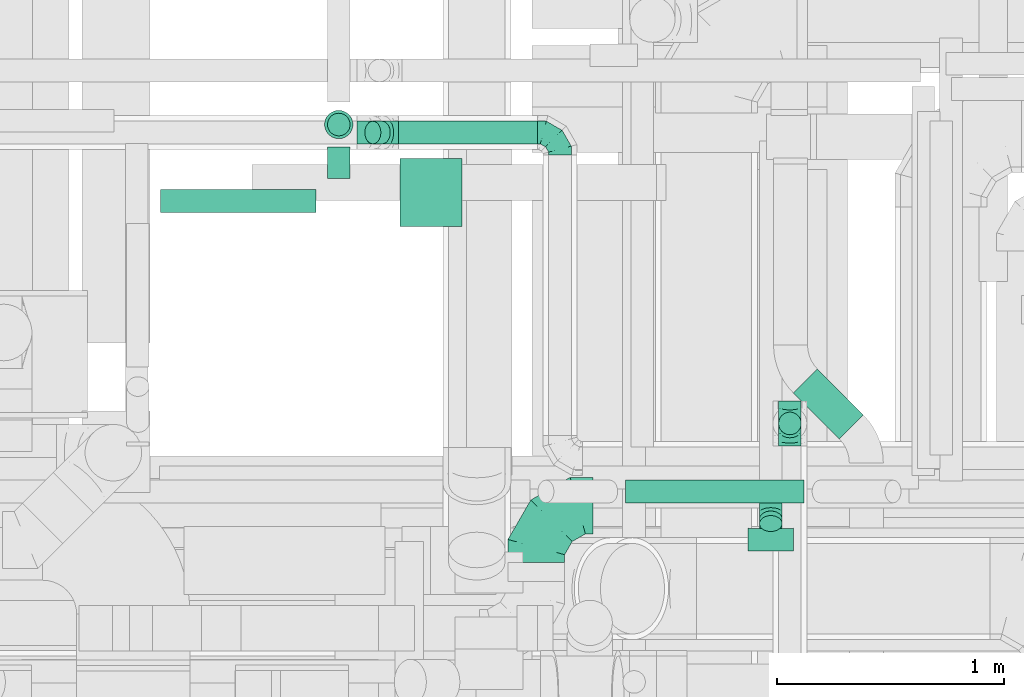
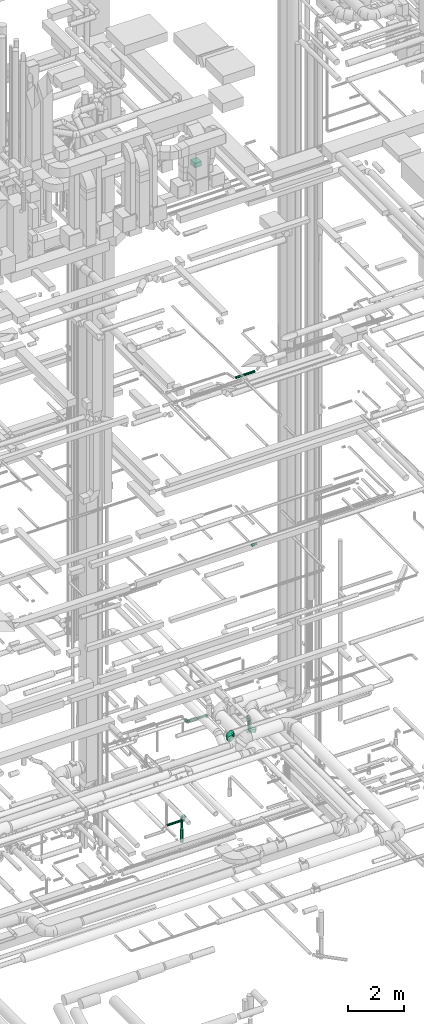
# One storey, part 255 of 337: 11 flow segments, 8 flow fittings.
"""IFC2X3 building model written with IfcOpenShell, lengths in millimetres."""

import ifcopenshell
import ifcopenshell.guid

model = None  # the IFC model being written
_history = None  # IfcOwnerHistory: only IFC2X3 demands one
_inside = {}  # id of a spatial element -> (the spatial element, [elements in it])
_under = {}  # id of a project, library or spatial element -> (it, [spatial elements below it])
_declared = {}  # id of a project -> (the project, [libraries it declares])
_typed = {}  # id of a type object -> (the type object, [elements of that type])
_made_of = {}  # id of a material, layer set ... -> (it, [elements and type objects made of it])


def new_model(schema):
    """Start an empty IFC model of exactly this schema.

    Asked for "IFC4X3", IfcOpenShell would pick the latest addendum, in which some entities
    have other attributes; the version numbers below select the first issue.
    IFC2X3 requires an IfcOwnerHistory on every rooted entity: one is made here for all.
    """
    global model, _history
    if schema == "IFC4X3":
        model = ifcopenshell.file(schema_version=(4, 3, 0, 0))
    else:
        model = ifcopenshell.file(schema=schema)
    _inside.clear()
    _under.clear()
    _declared.clear()
    _typed.clear()
    _made_of.clear()
    _history = None
    if model.schema == "IFC2X3":
        org = make("IfcOrganization", Name="unknown")
        user = make(
            "IfcPersonAndOrganization",
            ThePerson=make("IfcPerson", FamilyName="unknown"),
            TheOrganization=org,
        )
        app = make(
            "IfcApplication",
            ApplicationDeveloper=org,
            Version="unknown",
            ApplicationFullName="unknown",
            ApplicationIdentifier="unknown",
        )
        _history = make(
            "IfcOwnerHistory",
            OwningUser=user,
            OwningApplication=app,
            ChangeAction="ADDED",
            CreationDate=0,
        )
    return model


def make(cls, **values):
    """One entity of the class cls with the attributes given. An attribute that is None is left unset."""
    return model.create_entity(
        cls, **{name: value for name, value in values.items() if value is not None}
    )


def entity(cls, *values):
    """Any entity or typed value of the class cls, its attributes in the order of the schema. None: left unset."""
    e = model.create_entity(cls)
    for i, value in enumerate(values):
        if value is not None:
            e[i] = value
    return e


def rooted(cls, **values):
    """An entity with a GlobalId (a new one), such as an element, a storey or a relation."""
    return make(cls, GlobalId=ifcopenshell.guid.new(), OwnerHistory=_history, **values)


def si_unit(unit_type, name, prefix=None):
    """IfcSIUnit, for example si_unit("LENGTHUNIT", "METRE", prefix="MILLI")."""
    return make("IfcSIUnit", UnitType=unit_type, Prefix=prefix, Name=name)


def converted_unit(unit_type, name, factor, base, dimensions=None, offset=None):
    """IfcConversionBasedUnit, such as the inch: factor (a typed value) times the base unit."""
    return make(
        "IfcConversionBasedUnit"
        if offset is None
        else "IfcConversionBasedUnitWithOffset",
        ConversionOffset=offset,
        Dimensions=None
        if dimensions is None
        else entity("IfcDimensionalExponents", *dimensions),
        UnitType=unit_type,
        Name=name,
        ConversionFactor=make(
            "IfcMeasureWithUnit", ValueComponent=factor, UnitComponent=base
        ),
    )


def derived_unit(unit_type, elements):
    """IfcDerivedUnit: a product of units, each with its exponent."""
    return make(
        "IfcDerivedUnit",
        Elements=[
            make("IfcDerivedUnitElement", Unit=unit, Exponent=power)
            for unit, power in elements
        ],
        UnitType=unit_type,
    )


def assignment(units):
    """IfcUnitAssignment: the units of a project."""
    return None if units is None else make("IfcUnitAssignment", Units=units)


def point(xyz):
    """IfcCartesianPoint."""
    return None if xyz is None else make("IfcCartesianPoint", Coordinates=xyz)


def direction(xyz):
    """IfcDirection."""
    return None if xyz is None else make("IfcDirection", DirectionRatios=xyz)


def frame(location, z_axis=None, x_axis=None):
    """IfcAxis2Placement3D, a coordinate frame: its origin and axes. An axis left out is left unset."""
    return make(
        "IfcAxis2Placement3D",
        Location=point(location),
        Axis=direction(z_axis),
        RefDirection=direction(x_axis),
    )


def frame_2d(location, x_axis=None):
    """IfcAxis2Placement2D, a coordinate frame in the plane: its origin and x axis."""
    return make(
        "IfcAxis2Placement2D", Location=point(location), RefDirection=direction(x_axis)
    )


def origin():
    """The frame at (0, 0, 0) with its axes left unset."""
    return frame((0.0, 0.0, 0.0))


def origin_2d_with_axis():
    """The frame at (0, 0) in the plane with the x axis (1, 0) written out."""
    return frame_2d((0.0, 0.0), x_axis=(1.0, 0.0))


def place(relative_to, where):
    """IfcLocalPlacement: puts the frame where relative to a parent placement (None: the world)."""
    return make(
        "IfcLocalPlacement", PlacementRelTo=relative_to, RelativePlacement=where
    )


def context(
    kind, dimensions, precision=None, world=None, true_north=None, identifier=None
):
    """IfcGeometricRepresentationContext, for example the 3D "Model" context."""
    return make(
        "IfcGeometricRepresentationContext",
        ContextIdentifier=identifier,
        ContextType=kind,
        CoordinateSpaceDimension=dimensions,
        Precision=precision,
        WorldCoordinateSystem=world,
        TrueNorth=true_north,
    )


def subcontext(parent, identifier, kind, view, scale=None):
    """IfcGeometricRepresentationSubContext, for example "Body" below "Model"."""
    return make(
        "IfcGeometricRepresentationSubContext",
        ContextIdentifier=identifier,
        ContextType=kind,
        ParentContext=parent,
        TargetScale=scale,
        TargetView=view,
    )


def project(units=None, contexts=None):
    """IfcProject with its units and contexts."""
    return rooted(
        "IfcProject",
        Name="project",
        RepresentationContexts=contexts,
        UnitsInContext=assignment(units),
    )


def spatial(cls, under=None, at=None, **own):
    """A site, building, storey or space (cls), placed at a placement, below another one or the project."""
    s = rooted(cls, ObjectPlacement=at, **own)
    if under is not None:
        _under.setdefault(under.id(), (under, []))[1].append(s)
    return s


def profile(cls, at=None, kind="AREA", **sizes):
    """A parametric profile (cls). Its sizes go by their IFC names, for example OverallWidth=200.0."""
    return make(cls, ProfileType=kind, Position=at, **sizes)


def rectangle(**sizes):
    """IfcRectangleProfileDef."""
    return profile("IfcRectangleProfileDef", **sizes)


def circle(**sizes):
    """IfcCircleProfileDef."""
    return profile("IfcCircleProfileDef", **sizes)


def extrude(swept, where, along, depth):
    """IfcExtrudedAreaSolid: the profile swept, set in the frame where, extruded along a direction by depth."""
    return make(
        "IfcExtrudedAreaSolid",
        SweptArea=swept,
        Position=where,
        ExtrudedDirection=direction(along),
        Depth=depth,
    )


def faces_of(points, faces, orient=None, outer=None):
    """IfcFace entities. A face is a list of loops; a loop is a list of indices into points, from 0.

    orient and outer hold one flag for each loop. By default every Orientation is true, the
    first loop of a face is its IfcFaceOuterBound and the others are IfcFaceBound.
    """
    made = []
    for i, loops in enumerate(faces):
        bounds = []
        for j, loop in enumerate(loops):
            is_outer = j == 0 if outer is None else outer[i][j]
            bounds.append(
                make(
                    "IfcFaceOuterBound" if is_outer else "IfcFaceBound",
                    Bound=make("IfcPolyLoop", Polygon=[points[k] for k in loop]),
                    Orientation=True if orient is None else orient[i][j],
                )
            )
        made.append(make("IfcFace", Bounds=bounds))
    return made


def faceted_brep(points, faces, orient=None, outer=None, voids=None):
    """IfcFacetedBrep: a solid bounded by flat faces; with voids (closed shells), ...WithVoids."""
    shared = [point(p) for p in points]
    hull = make("IfcClosedShell", CfsFaces=faces_of(shared, faces, orient, outer))
    if voids is None:
        return make("IfcFacetedBrep", Outer=hull)
    return make(
        "IfcFacetedBrepWithVoids",
        Outer=hull,
        Voids=[
            make(cls, CfsFaces=faces_of(shared, fs, o, b)) for cls, fs, o, b in voids
        ],
    )


def shape(context_of_items, identifier, shape_type, items):
    """IfcShapeRepresentation: the items that make up one representation, for example the "Body"."""
    return make(
        "IfcShapeRepresentation",
        ContextOfItems=context_of_items,
        RepresentationIdentifier=identifier,
        RepresentationType=shape_type,
        Items=items,
    )


def source(mapping_origin, context_of_items, identifier, shape_type, items):
    """IfcRepresentationMap: a shape defined once, which mapped items show again and again."""
    return make(
        "IfcRepresentationMap",
        MappingOrigin=mapping_origin,
        MappedRepresentation=shape(context_of_items, identifier, shape_type, items),
    )


def transform(
    local_origin,
    x_axis=None,
    y_axis=None,
    z_axis=None,
    scale=None,
    scale2=None,
    scale3=None,
    uniform=True,
):
    """IfcCartesianTransformationOperator3D, or its non-uniform kind. x_axis, y_axis, z_axis: its Axis1, 2, 3."""
    if uniform:
        return make(
            "IfcCartesianTransformationOperator3D",
            Axis1=direction(x_axis),
            Axis2=direction(y_axis),
            LocalOrigin=point(local_origin),
            Scale=scale,
            Axis3=direction(z_axis),
        )
    return make(
        "IfcCartesianTransformationOperator3DnonUniform",
        Axis1=direction(x_axis),
        Axis2=direction(y_axis),
        LocalOrigin=point(local_origin),
        Scale=scale,
        Axis3=direction(z_axis),
        Scale2=scale2,
        Scale3=scale3,
    )


def mapped(mapping_source, mapping_target):
    """IfcMappedItem: shows the shape of a source again, moved by a transform."""
    return make(
        "IfcMappedItem", MappingSource=mapping_source, MappingTarget=mapping_target
    )


def material(Name=None, Category=None):
    """IfcMaterial."""
    return make("IfcMaterial", Name=Name, Category=Category)


def made_of(thing, what):
    """Note that an element or type object is made of a material, layer set ...; save() writes the relation."""
    if what is not None:
        _made_of.setdefault(what.id(), (what, []))[1].append(thing)
    return thing


def type_object(cls, material=None, **own):
    """A type object (cls), such as IfcWallType, which elements share."""
    return made_of(rooted(cls, **own), material)


def type_shapes(of_type, sources):
    """Give a type object the sources (RepresentationMaps) that its elements show as mapped items."""
    of_type.RepresentationMaps = sources


def element(
    cls,
    number,
    at=None,
    inside=None,
    cuts=None,
    type_object=None,
    material=None,
    context=None,
    identifier="Body",
    shape_type=None,
    held_by="IfcProductDefinitionShape",
    body=None,
    shapes=None,
    **own,
):
    """One element of the class cls, such as IfcWall. Its Tag is "e" and its number.

    at: its placement. inside: the storey or other place that contains it. cuts: it is an
    opening in that element (IfcRelVoidsElement). A single representation is given by context,
    identifier, shape_type and body (its items); several are given by shapes. held_by: the class
    of the entity that holds the representations. save() writes the other relations.
    """
    e = rooted(cls, Tag="e%d" % number, ObjectPlacement=at, **own)
    if body is not None:
        shapes = [shape(context, identifier, shape_type, body)]
    if shapes is not None:
        e.Representation = make(held_by, Representations=shapes)
    if inside is not None:
        _inside.setdefault(inside.id(), (inside, []))[1].append(e)
    if cuts is not None:
        rooted(
            "IfcRelVoidsElement", RelatingBuildingElement=cuts, RelatedOpeningElement=e
        )
    if type_object is not None:
        _typed.setdefault(type_object.id(), (type_object, []))[1].append(e)
    return made_of(e, material)


def aggregate(whole, parts):
    """IfcRelAggregates: a whole, such as a stair, and the parts it consists of."""
    return rooted("IfcRelAggregates", RelatingObject=whole, RelatedObjects=parts)


def save(model, path):
    """Write the relations noted so far, then the file.

    IfcRelAggregates (storeys below a building ...), IfcRelContainedInSpatialStructure (elements
    in a storey), IfcRelDefinesByType, IfcRelAssociatesMaterial and IfcRelDeclares: one each for
    every whole, place, type object, material and project.
    """
    for whole, parts in _under.values():
        aggregate(whole, parts)
    for where, things in _inside.values():
        rooted(
            "IfcRelContainedInSpatialStructure",
            RelatedElements=things,
            RelatingStructure=where,
        )
    for kind, things in _typed.values():
        rooted("IfcRelDefinesByType", RelatedObjects=things, RelatingType=kind)
    for what, things in _made_of.values():
        rooted("IfcRelAssociatesMaterial", RelatedObjects=things, RelatingMaterial=what)
    for by, libraries in _declared.values():
        rooted("IfcRelDeclares", RelatingContext=by, RelatedDefinitions=libraries)
    model.write(path)


model = new_model("IFC2X3")

# Units and contexts
model_context = context("Model", 3, precision=0.01, world=origin(), true_north=direction((6.12303176911189e-17, 1.0)))
body_context = subcontext(model_context, "Body", "Model", "MODEL_VIEW")
ifc_project = project(units=[si_unit("LENGTHUNIT", "METRE", prefix="MILLI"), si_unit("AREAUNIT", "SQUARE_METRE"), si_unit("VOLUMEUNIT", "CUBIC_METRE"), converted_unit("PLANEANGLEUNIT", "DEGREE", entity("IfcRatioMeasure", 0.0174532925199433), si_unit("PLANEANGLEUNIT", "RADIAN"), dimensions=[0, 0, 0, 0, 0, 0, 0]), si_unit("MASSUNIT", "GRAM", prefix="KILO"), derived_unit("MASSDENSITYUNIT", [(si_unit("MASSUNIT", "GRAM", prefix="KILO"), 1), (si_unit("LENGTHUNIT", "METRE"), -3)]), derived_unit("MOMENTOFINERTIAUNIT", [(si_unit("LENGTHUNIT", "METRE"), 4)]), si_unit("TIMEUNIT", "SECOND"), si_unit("FREQUENCYUNIT", "HERTZ"), si_unit("THERMODYNAMICTEMPERATUREUNIT", "DEGREE_CELSIUS"), derived_unit("THERMALTRANSMITTANCEUNIT", [(si_unit("MASSUNIT", "GRAM", prefix="KILO"), 1), (si_unit("THERMODYNAMICTEMPERATUREUNIT", "KELVIN"), -1), (si_unit("TIMEUNIT", "SECOND"), -3)]), derived_unit("VOLUMETRICFLOWRATEUNIT", [(si_unit("LENGTHUNIT", "METRE"), 3), (si_unit("TIMEUNIT", "SECOND"), -1)]), derived_unit("MASSFLOWRATEUNIT", [(si_unit("MASSUNIT", "GRAM", prefix="KILO"), 1), (si_unit("TIMEUNIT", "SECOND"), -1)]), derived_unit("ROTATIONALFREQUENCYUNIT", [(si_unit("TIMEUNIT", "SECOND"), -1)]), si_unit("ELECTRICCURRENTUNIT", "AMPERE"), si_unit("ELECTRICVOLTAGEUNIT", "VOLT"), si_unit("POWERUNIT", "WATT"), si_unit("FORCEUNIT", "NEWTON", prefix="KILO"), si_unit("ILLUMINANCEUNIT", "LUX"), si_unit("LUMINOUSFLUXUNIT", "LUMEN"), si_unit("LUMINOUSINTENSITYUNIT", "CANDELA"), derived_unit("USERDEFINED", [(si_unit("MASSUNIT", "GRAM", prefix="KILO"), -1), (si_unit("LENGTHUNIT", "METRE"), -2), (si_unit("TIMEUNIT", "SECOND"), 3), (si_unit("LUMINOUSFLUXUNIT", "LUMEN"), 1)]), derived_unit("LINEARVELOCITYUNIT", [(si_unit("LENGTHUNIT", "METRE"), 1), (si_unit("TIMEUNIT", "SECOND"), -1)]), si_unit("PRESSUREUNIT", "PASCAL"), derived_unit("USERDEFINED", [(si_unit("LENGTHUNIT", "METRE"), -2), (si_unit("MASSUNIT", "GRAM", prefix="KILO"), 1), (si_unit("TIMEUNIT", "SECOND"), -2)]), derived_unit("LINEARFORCEUNIT", [(si_unit("MASSUNIT", "GRAM", prefix="KILO"), 1), (si_unit("LENGTHUNIT", "METRE"), 1), (si_unit("TIMEUNIT", "SECOND"), -2), (si_unit("LENGTHUNIT", "METRE"), -1)]), derived_unit("PLANARFORCEUNIT", [(si_unit("MASSUNIT", "GRAM", prefix="KILO"), 1), (si_unit("LENGTHUNIT", "METRE"), 1), (si_unit("TIMEUNIT", "SECOND"), -2), (si_unit("LENGTHUNIT", "METRE"), -2)])], contexts=[model_context])

# Site, building, storey
site_placement = place(None, origin())
site = spatial("IfcSite", under=ifc_project, at=site_placement, CompositionType="ELEMENT")
building_placement = place(site_placement, origin())
building = spatial("IfcBuilding", under=site, at=building_placement, CompositionType="ELEMENT")
storey_placement = place(building_placement, origin())
storey = spatial("IfcBuildingStorey", under=building, at=storey_placement, CompositionType="ELEMENT", Elevation=0.0)

# Flow segments
duct_segment_type_1 = type_object("IfcDuctSegmentType", PredefinedType="NOTDEFINED")
flow_segment_1_placement = place(storey_placement, frame((63295.52, 11348.91, 27525.0)))
element("IfcFlowSegment", 1, at=flow_segment_1_placement, inside=storey, type_object=duct_segment_type_1, context=body_context, shape_type="SweptSolid", body=[
    extrude(rectangle(XDim=274.500000000016, YDim=300.000000000001, at=origin_2d_with_axis()), frame((137.25, 150.0, 0.0), z_axis=(0.0, 0.0, 1.0), x_axis=(-1.0, 0.0, 0.0)), (0.0, 0.0, 1.0), 199.999999999998),
])
flow_segment_2_placement = place(storey_placement, frame((65032.36, 10410.46, 2975.0)))
element("IfcFlowSegment", 2, at=flow_segment_2_placement, inside=storey, type_object=duct_segment_type_1, context=body_context, shape_type="SweptSolid", body=[
    extrude(rectangle(XDim=286.740981921751, YDim=149.999999999996, at=origin_2d_with_axis()), frame((154.41, 154.41, 0.0), z_axis=(0.0, 0.0, 1.0), x_axis=(-0.707106781186551, 0.707106781186544, 0.0)), (0.0, 0.0, 1.0), 149.999999999999),
])
duct_segment_type_2 = type_object("IfcDuctSegmentType", PredefinedType="NOTDEFINED")
flow_segment_3_placement = place(storey_placement, frame((62240.26, 11408.94, -651.6)))
element("IfcFlowSegment", 3, at=flow_segment_3_placement, inside=storey, type_object=duct_segment_type_2, context=body_context, shape_type="SweptSolid", body=[
    extrude(circle(Radius=50.0, at=origin_2d_with_axis()), frame((0.0, 51.6, 51.6), z_axis=(1.0, 0.0, 0.0), x_axis=(0.0, -1.0, 0.0)), (0.0, 0.0, 1.0), 686.270819999998),
])
flow_segment_4_placement = place(storey_placement, frame((62974.94, 11560.54, -651.6)))
element("IfcFlowSegment", 4, at=flow_segment_4_placement, inside=storey, type_object=duct_segment_type_2, context=body_context, shape_type="SweptSolid", body=[
    extrude(circle(Radius=50.0, at=origin_2d_with_axis()), frame((51.6, 0.0, 51.6), z_axis=(0.0, 1.0, 0.0), x_axis=(1.0, 0.0, 0.0)), (0.0, 0.0, 1.0), 137.341930000023),
])
flow_segment_5_placement = place(storey_placement, frame((62974.94, 11746.29, -1176.74)))
element("IfcFlowSegment", 5, at=flow_segment_5_placement, inside=storey, type_object=duct_segment_type_2, context=body_context, shape_type="SweptSolid", body=[
    extrude(circle(Radius=50.0, at=origin_2d_with_axis()), frame((51.6, 51.6, 0.0), z_axis=(0.0, 0.0, 1.0), x_axis=(0.0, 1.0, 0.0)), (0.0, 0.0, 1.0), 476.736044499986),
])
flow_segment_6_placement = place(storey_placement, frame((62962.44, 11733.79, -1800.0)))
element("IfcFlowSegment", 6, at=flow_segment_6_placement, inside=storey, type_object=duct_segment_type_2, context=body_context, shape_type="SweptSolid", body=[
    extrude(circle(Radius=62.5, at=origin_2d_with_axis()), frame((64.1, 64.1, 0.0), z_axis=(0.0, 0.0, 1.0), x_axis=(0.0, 1.0, 0.0)), (0.0, 0.0, 1.0), 559.263955500005),
])
flow_segment_7_placement = place(storey_placement, frame((64292.48, 10127.45, 18768.4)))
element("IfcFlowSegment", 7, at=flow_segment_7_placement, inside=storey, type_object=duct_segment_type_2, context=body_context, shape_type="SweptSolid", body=[
    extrude(circle(Radius=50.0, at=origin_2d_with_axis()), frame((0.0, 51.6, 51.6), z_axis=(1.0, 0.0, 0.0), x_axis=(0.0, -1.0, 0.0)), (0.0, 0.0, 1.0), 787.157287525448),
])
flow_segment_8_placement = place(storey_placement, frame((63139.8, 11710.99, 3342.34)))
element("IfcFlowSegment", 8, at=flow_segment_8_placement, inside=storey, type_object=duct_segment_type_2, context=body_context, shape_type="SweptSolid", body=[
    extrude(circle(Radius=50.0, at=origin_2d_with_axis()), frame((78.37, 51.6, 36.95), z_axis=(-0.707106781186399, 0.0, 0.707106781186696), x_axis=(0.0, -1.0, 0.0)), (0.0, 0.0, 1.0), 58.5786437626603),
])
flow_segment_9_placement = place(storey_placement, frame((63288.88, 11710.99, 3298.4)))
element("IfcFlowSegment", 9, at=flow_segment_9_placement, inside=storey, type_object=duct_segment_type_2, context=body_context, shape_type="SweptSolid", body=[
    extrude(circle(Radius=50.0, at=origin_2d_with_axis()), frame((0.0, 51.6, 51.6), z_axis=(1.0, 0.0, 0.0), x_axis=(0.0, 1.0, 0.0)), (0.0, 0.0, 1.0), 613.303163484644),
])
flow_segment_10_placement = place(storey_placement, frame((64965.15, 10427.54, 3200.0)))
element("IfcFlowSegment", 10, at=flow_segment_10_placement, inside=storey, type_object=duct_segment_type_2, context=body_context, shape_type="SweptSolid", body=[
    extrude(circle(Radius=50.0, at=origin_2d_with_axis()), frame((51.6, 51.6, 0.0), z_axis=(0.0, 0.0, 1.0), x_axis=(-1.0, 0.0, 0.0)), (0.0, 0.0, 1.0), 350.000000000003),
])
flow_segment_11_placement = place(storey_placement, frame((64880.89, 10000.55, 11392.34)))
element("IfcFlowSegment", 11, at=flow_segment_11_placement, inside=storey, type_object=duct_segment_type_2, context=body_context, shape_type="SweptSolid", body=[
    extrude(circle(Radius=50.0, at=origin_2d_with_axis()), frame((51.6, 36.95, 56.95), z_axis=(0.0, 0.707106781186548, -0.707106781186548), x_axis=(-1.0, 0.0, 0.0)), (0.0, 0.0, 1.0), 28.2842712474572),
])

# Flow fittings
ifc_material = material()
duct_fitting_type_1 = type_object("IfcDuctFittingType", PredefinedType="NOTDEFINED", material=ifc_material)
shared_shape_1 = source(origin(), body_context, "Body", "Brep", [
    faceted_brep([(-100.0, 0.0, -50.0), (-100.0, -12.94, -48.3), (-100.0, -25.0, -43.3), (-100.0, -35.36, -35.36), (-100.0, -43.3, -25.0), (-100.0, -48.3, -12.94), (-100.0, -50.0, 0.0), (-100.0, -48.3, 12.94), (-100.0, -43.3, 25.0), (-100.0, -35.36, 35.36), (-100.0, -25.0, 43.3), (-100.0, -12.94, 48.3), (-100.0, 0.0, 50.0), (-100.0, 12.94, 48.3), (-100.0, 25.0, 43.3), (-100.0, 35.36, 35.36), (-100.0, 43.3, 25.0), (-100.0, 48.3, 12.94), (-100.0, 50.0, 0.0), (-100.0, 48.3, -12.94), (-100.0, 43.3, -25.0), (-100.0, 35.36, -35.36), (-100.0, 25.0, -43.3), (-100.0, 12.94, -48.3), (-76.67, 12.94, 48.3), (-79.9, 25.0, 43.3), (-73.21, 0.0, 50.0), (-82.68, 35.36, 35.36), (-86.15, 48.3, 12.94), (-86.6, 50.0, 0.0), (-84.81, 43.3, 25.0), (-84.81, 43.3, -25.0), (-82.68, 35.36, -35.36), (-86.15, 48.3, -12.94), (-76.67, 12.94, -48.3), (-73.21, 0.0, -50.0), (-79.9, 25.0, -43.3), (-69.74, -12.94, -48.3), (-66.51, -25.0, -43.3), (-63.73, -35.36, -35.36), (-61.6, -43.3, -25.0), (-60.26, -48.3, -12.94), (-59.81, -50.0, 0.0), (-60.26, -48.3, 12.94), (-61.6, -43.3, 25.0), (-63.73, -35.36, 35.36), (-66.51, -25.0, 43.3), (-69.74, -12.94, 48.3), (-36.27, 36.27, 48.3), (-45.1, 45.1, 43.3), (-26.79, 26.79, 50.0), (-52.68, 52.68, 35.36), (-58.49, 58.49, 25.0), (-62.15, 62.15, 12.94), (-63.4, 63.4, 0.0), (-62.15, 62.15, -12.94), (-58.49, 58.49, -25.0), (-52.68, 52.68, -35.36), (-36.27, 36.27, -48.3), (-26.79, 26.79, -50.0), (-45.1, 45.1, -43.3), (-17.32, 17.32, -48.3), (-8.49, 8.49, -43.3), (-0.91, 0.91, -35.36), (4.9, -4.9, -25.0), (8.56, -8.56, -12.94), (9.81, -9.81, 0.0), (8.56, -8.56, 12.94), (4.9, -4.9, 25.0), (-0.91, 0.91, 35.36), (-8.49, 8.49, 43.3), (-17.32, 17.32, 48.3), (-12.94, 76.67, 48.3), (-25.0, 79.9, 43.3), (0.0, 73.21, 50.0), (-35.36, 82.68, 35.36), (-43.3, 84.81, 25.0), (-48.3, 86.15, 12.94), (-50.0, 86.6, 0.0), (-48.3, 86.15, -12.94), (-43.3, 84.81, -25.0), (-35.36, 82.68, -35.36), (-12.94, 76.67, -48.3), (0.0, 73.21, -50.0), (-25.0, 79.9, -43.3), (12.94, 69.74, -48.3), (25.0, 66.51, -43.3), (35.36, 63.73, -35.36), (43.3, 61.6, -25.0), (48.3, 60.26, -12.94), (50.0, 59.81, 0.0), (48.3, 60.26, 12.94), (43.3, 61.6, 25.0), (35.36, 63.73, 35.36), (25.0, 66.51, 43.3), (12.94, 69.74, 48.3), (-12.94, 100.0, -48.3), (-25.0, 100.0, -43.3), (-35.36, 100.0, -35.36), (-43.3, 100.0, -25.0), (-48.3, 100.0, -12.94), (-50.0, 100.0, 0.0), (-48.3, 100.0, 12.94), (-43.3, 100.0, 25.0), (-35.36, 100.0, 35.36), (-25.0, 100.0, 43.3), (-12.94, 100.0, 48.3), (0.0, 100.0, 50.0), (12.94, 100.0, 48.3), (25.0, 100.0, 43.3), (35.36, 100.0, 35.36), (43.3, 100.0, 25.0), (48.3, 100.0, 12.94), (50.0, 100.0, 0.0), (48.3, 100.0, -12.94), (43.3, 100.0, -25.0), (35.36, 100.0, -35.36), (25.0, 100.0, -43.3), (12.94, 100.0, -48.3), (0.0, 100.0, -50.0)], [[[0, 1, 2, 3, 4, 5, 6, 7, 8, 9, 10, 11, 12, 13, 14, 15, 16, 17, 18, 19, 20, 21, 22, 23]], [[24, 25, 14, 13]], [[26, 24, 13, 12]], [[14, 25, 27, 15]], [[28, 29, 18, 17]], [[30, 28, 17, 16]], [[15, 27, 30, 16]], [[20, 31, 32, 21]], [[33, 31, 20, 19]], [[18, 29, 33, 19]], [[34, 35, 0, 23]], [[36, 34, 23, 22]], [[32, 36, 22, 21]], [[2, 1, 37, 38]], [[3, 2, 38, 39]], [[0, 35, 37, 1]], [[5, 4, 40, 41]], [[6, 5, 41, 42]], [[3, 39, 40, 4]], [[6, 42, 43, 7]], [[7, 43, 44, 8]], [[8, 44, 45, 9]], [[10, 46, 47, 11]], [[11, 47, 26, 12]], [[10, 9, 45, 46]], [[48, 49, 25, 24]], [[50, 48, 24, 26]], [[27, 25, 49, 51]], [[52, 53, 28, 30]], [[51, 52, 30, 27]], [[29, 28, 53, 54]], [[55, 56, 31, 33]], [[54, 55, 33, 29]], [[57, 32, 31, 56]], [[58, 59, 35, 34]], [[60, 58, 34, 36]], [[57, 60, 36, 32]], [[37, 35, 59, 61]], [[38, 37, 61, 62]], [[39, 38, 62, 63]], [[41, 40, 64, 65]], [[42, 41, 65, 66]], [[63, 64, 40, 39]], [[43, 42, 66, 67]], [[44, 43, 67, 68]], [[68, 69, 45, 44]], [[46, 45, 69, 70]], [[47, 46, 70, 71]], [[26, 47, 71, 50]], [[72, 73, 49, 48]], [[74, 72, 48, 50]], [[51, 49, 73, 75]], [[76, 77, 53, 52]], [[75, 76, 52, 51]], [[54, 53, 77, 78]], [[79, 80, 56, 55]], [[78, 79, 55, 54]], [[81, 57, 56, 80]], [[82, 83, 59, 58]], [[84, 82, 58, 60]], [[81, 84, 60, 57]], [[61, 59, 83, 85]], [[62, 61, 85, 86]], [[63, 62, 86, 87]], [[65, 64, 88, 89]], [[66, 65, 89, 90]], [[87, 88, 64, 63]], [[67, 66, 90, 91]], [[68, 67, 91, 92]], [[92, 93, 69, 68]], [[70, 69, 93, 94]], [[71, 70, 94, 95]], [[50, 71, 95, 74]], [[96, 97, 98, 99, 100, 101, 102, 103, 104, 105, 106, 107, 108, 109, 110, 111, 112, 113, 114, 115, 116, 117, 118, 119]], [[72, 74, 107, 106]], [[73, 72, 106, 105]], [[75, 73, 105, 104]], [[77, 76, 103, 102]], [[78, 77, 102, 101]], [[75, 104, 103, 76]], [[78, 101, 100, 79]], [[79, 100, 99, 80]], [[80, 99, 98, 81]], [[96, 119, 83, 82]], [[97, 96, 82, 84]], [[84, 81, 98, 97]], [[83, 119, 118, 85]], [[85, 118, 117, 86]], [[86, 117, 116, 87]], [[88, 115, 114, 89]], [[89, 114, 113, 90]], [[87, 116, 115, 88]], [[91, 90, 113, 112]], [[92, 91, 112, 111]], [[93, 92, 111, 110]], [[95, 94, 109, 108]], [[74, 95, 108, 107]], [[110, 109, 94, 93]]]),
])
type_shapes(duct_fitting_type_1, [shared_shape_1])
for number, where, z_axis, x_axis in (
    (12, (64002.18, 11762.59, 3350.0), (0.0, 0.0, 1.0), (0.0, 1.0, 0.0)),
    (13, (65016.74, 10479.14, 3100.0), (1.0, 0.0, 0.0), (0.0, 1.0, 0.0)),
    (14, (65016.74, 10479.14, 3650.0), (-1.0, 0.0, 0.0), (0.0, 0.0, 1.0)),
):
    element("IfcFlowFitting", number, at=place(storey_placement, frame(where, z_axis=z_axis, x_axis=x_axis)), inside=storey, type_object=duct_fitting_type_1, material=ifc_material, context=body_context, shape_type="MappedRepresentation", body=[
        mapped(shared_shape_1, transform((0.0, 0.0, 0.0), scale=1.0)),
    ])
duct_fitting_type_2 = type_object("IfcDuctFittingType", PredefinedType="NOTDEFINED", material=ifc_material)
shared_shape_2 = source(origin(), body_context, "Body", "Brep", [
    faceted_brep([(-250.0, 0.0, -125.0), (-250.0, -32.35, -120.74), (-250.0, -62.5, -108.25), (-250.0, -88.39, -88.39), (-250.0, -108.25, -62.5), (-250.0, -120.74, -32.35), (-250.0, -125.0, 0.0), (-250.0, -120.74, 32.35), (-250.0, -108.25, 62.5), (-250.0, -88.39, 88.39), (-250.0, -62.5, 108.25), (-250.0, -32.35, 120.74), (-250.0, 0.0, 125.0), (-250.0, 32.35, 120.74), (-250.0, 62.5, 108.25), (-250.0, 88.39, 88.39), (-250.0, 108.25, 62.5), (-250.0, 120.74, 32.35), (-250.0, 125.0, 0.0), (-250.0, 120.74, -32.35), (-250.0, 108.25, -62.5), (-250.0, 88.39, -88.39), (-250.0, 62.5, -108.25), (-250.0, 32.35, -120.74), (-191.68, 32.35, 120.74), (-199.76, 62.5, 108.25), (-183.01, 0.0, 125.0), (-206.7, 88.39, 88.39), (-215.37, 120.74, 32.35), (-216.51, 125.0, 0.0), (-212.02, 108.25, 62.5), (-212.02, 108.25, -62.5), (-206.7, 88.39, -88.39), (-215.37, 120.74, -32.35), (-191.68, 32.35, -120.74), (-183.01, 0.0, -125.0), (-199.76, 62.5, -108.25), (-174.34, -32.35, -120.74), (-166.27, -62.5, -108.25), (-159.33, -88.39, -88.39), (-154.01, -108.25, -62.5), (-150.66, -120.74, -32.35), (-149.52, -125.0, 0.0), (-150.66, -120.74, 32.35), (-154.01, -108.25, 62.5), (-159.33, -88.39, 88.39), (-166.27, -62.5, 108.25), (-174.34, -32.35, 120.74), (-90.67, 90.67, 120.74), (-112.74, 112.74, 108.25), (-66.99, 66.99, 125.0), (-131.69, 131.69, 88.39), (-146.23, 146.23, 62.5), (-155.38, 155.38, 32.35), (-158.49, 158.49, 0.0), (-155.38, 155.38, -32.35), (-146.23, 146.23, -62.5), (-131.69, 131.69, -88.39), (-90.67, 90.67, -120.74), (-66.99, 66.99, -125.0), (-112.74, 112.74, -108.25), (-43.3, 43.3, -120.74), (-21.23, 21.23, -108.25), (-2.28, 2.28, -88.39), (12.26, -12.26, -62.5), (21.4, -21.4, -32.35), (24.52, -24.52, 0.0), (21.4, -21.4, 32.35), (12.26, -12.26, 62.5), (-2.28, 2.28, 88.39), (-21.23, 21.23, 108.25), (-43.3, 43.3, 120.74), (-32.35, 191.68, 120.74), (-62.5, 199.76, 108.25), (0.0, 183.01, 125.0), (-88.39, 206.7, 88.39), (-108.25, 212.02, 62.5), (-120.74, 215.37, 32.35), (-125.0, 216.51, 0.0), (-120.74, 215.37, -32.35), (-108.25, 212.02, -62.5), (-88.39, 206.7, -88.39), (-32.35, 191.68, -120.74), (0.0, 183.01, -125.0), (-62.5, 199.76, -108.25), (32.35, 174.34, -120.74), (62.5, 166.27, -108.25), (88.39, 159.33, -88.39), (108.25, 154.01, -62.5), (120.74, 150.66, -32.35), (125.0, 149.52, 0.0), (120.74, 150.66, 32.35), (108.25, 154.01, 62.5), (88.39, 159.33, 88.39), (62.5, 166.27, 108.25), (32.35, 174.34, 120.74), (-32.35, 250.0, -120.74), (-62.5, 250.0, -108.25), (-88.39, 250.0, -88.39), (-108.25, 250.0, -62.5), (-120.74, 250.0, -32.35), (-125.0, 250.0, 0.0), (-120.74, 250.0, 32.35), (-108.25, 250.0, 62.5), (-88.39, 250.0, 88.39), (-62.5, 250.0, 108.25), (-32.35, 250.0, 120.74), (0.0, 250.0, 125.0), (32.35, 250.0, 120.74), (62.5, 250.0, 108.25), (88.39, 250.0, 88.39), (108.25, 250.0, 62.5), (120.74, 250.0, 32.35), (125.0, 250.0, 0.0), (120.74, 250.0, -32.35), (108.25, 250.0, -62.5), (88.39, 250.0, -88.39), (62.5, 250.0, -108.25), (32.35, 250.0, -120.74), (0.0, 250.0, -125.0)], [[[0, 1, 2, 3, 4, 5, 6, 7, 8, 9, 10, 11, 12, 13, 14, 15, 16, 17, 18, 19, 20, 21, 22, 23]], [[24, 25, 14, 13]], [[26, 24, 13, 12]], [[14, 25, 27, 15]], [[28, 29, 18, 17]], [[30, 28, 17, 16]], [[15, 27, 30, 16]], [[20, 31, 32, 21]], [[33, 31, 20, 19]], [[18, 29, 33, 19]], [[34, 35, 0, 23]], [[36, 34, 23, 22]], [[21, 32, 36, 22]], [[1, 0, 35, 37]], [[2, 1, 37, 38]], [[38, 39, 3, 2]], [[5, 4, 40, 41]], [[6, 5, 41, 42]], [[39, 40, 4, 3]], [[6, 42, 43, 7]], [[7, 43, 44, 8]], [[8, 44, 45, 9]], [[9, 45, 46, 10]], [[10, 46, 47, 11]], [[26, 12, 11, 47]], [[48, 49, 25, 24]], [[50, 48, 24, 26]], [[27, 25, 49, 51]], [[52, 53, 28, 30]], [[51, 52, 30, 27]], [[29, 28, 53, 54]], [[55, 56, 31, 33]], [[54, 55, 33, 29]], [[32, 31, 56, 57]], [[58, 59, 35, 34]], [[60, 58, 34, 36]], [[57, 60, 36, 32]], [[37, 35, 59, 61]], [[38, 37, 61, 62]], [[39, 38, 62, 63]], [[41, 40, 64, 65]], [[42, 41, 65, 66]], [[63, 64, 40, 39]], [[43, 42, 66, 67]], [[44, 43, 67, 68]], [[68, 69, 45, 44]], [[46, 45, 69, 70]], [[47, 46, 70, 71]], [[26, 47, 71, 50]], [[72, 73, 49, 48]], [[74, 72, 48, 50]], [[51, 49, 73, 75]], [[76, 77, 53, 52]], [[75, 76, 52, 51]], [[54, 53, 77, 78]], [[79, 80, 56, 55]], [[78, 79, 55, 54]], [[57, 56, 80, 81]], [[82, 83, 59, 58]], [[84, 82, 58, 60]], [[81, 84, 60, 57]], [[61, 59, 83, 85]], [[62, 61, 85, 86]], [[63, 62, 86, 87]], [[65, 64, 88, 89]], [[66, 65, 89, 90]], [[87, 88, 64, 63]], [[67, 66, 90, 91]], [[68, 67, 91, 92]], [[92, 93, 69, 68]], [[70, 69, 93, 94]], [[71, 70, 94, 95]], [[50, 71, 95, 74]], [[96, 97, 98, 99, 100, 101, 102, 103, 104, 105, 106, 107, 108, 109, 110, 111, 112, 113, 114, 115, 116, 117, 118, 119]], [[72, 74, 107, 106]], [[73, 72, 106, 105]], [[75, 73, 105, 104]], [[77, 76, 103, 102]], [[78, 77, 102, 101]], [[75, 104, 103, 76]], [[78, 101, 100, 79]], [[79, 100, 99, 80]], [[80, 99, 98, 81]], [[84, 97, 96, 82]], [[82, 96, 119, 83]], [[84, 81, 98, 97]], [[83, 119, 118, 85]], [[85, 118, 117, 86]], [[116, 87, 86, 117]], [[88, 115, 114, 89]], [[89, 114, 113, 90]], [[115, 88, 87, 116]], [[91, 90, 113, 112]], [[92, 91, 112, 111]], [[111, 110, 93, 92]], [[95, 94, 109, 108]], [[74, 95, 108, 107]], [[110, 109, 94, 93]]]),
])
type_shapes(duct_fitting_type_2, [shared_shape_2])
flow_fitting_1_placement = place(storey_placement, frame((63897.96, 10116.68, 3520.0), z_axis=(0.0, 0.0, 1.0), x_axis=(-1.0, 0.0, 0.0)))
element("IfcFlowFitting", 15, at=flow_fitting_1_placement, inside=storey, type_object=duct_fitting_type_2, material=ifc_material, context=body_context, shape_type="MappedRepresentation", body=[
    mapped(shared_shape_2, transform((0.0, 0.0, 0.0), scale=1.0)),
])
duct_fitting_type_3 = type_object("IfcDuctFittingType", PredefinedType="NOTDEFINED", material=ifc_material)
shared_shape_3 = source(origin(), body_context, "Body", "Brep", [
    faceted_brep([(-41.42, 0.0, -50.0), (-41.42, -12.94, -48.3), (-41.42, -25.0, -43.3), (-41.42, -35.36, -35.36), (-41.42, -43.3, -25.0), (-41.42, -48.3, -12.94), (-41.42, -50.0, 0.0), (-41.42, -48.3, 12.94), (-41.42, -43.3, 25.0), (-41.42, -35.36, 35.36), (-41.42, -25.0, 43.3), (-41.42, -12.94, 48.3), (-41.42, 0.0, 50.0), (-41.42, 12.94, 48.3), (-41.42, 25.0, 43.3), (-41.42, 35.36, 35.36), (-41.42, 43.3, 25.0), (-41.42, 48.3, 12.94), (-41.42, 50.0, 0.0), (-41.42, 48.3, -12.94), (-41.42, 43.3, -25.0), (-41.42, 35.36, -35.36), (-41.42, 25.0, -43.3), (-41.42, 12.94, -48.3), (-5.36, 12.94, 48.3), (-10.36, 25.0, 43.3), (0.0, 0.0, 50.0), (-14.64, 35.36, 35.36), (-20.0, 48.3, 12.94), (-20.71, 50.0, 0.0), (-17.94, 43.3, 25.0), (-17.94, 43.3, -25.0), (-14.64, 35.36, -35.36), (-20.0, 48.3, -12.94), (-5.36, 12.94, -48.3), (0.0, 0.0, -50.0), (-10.36, 25.0, -43.3), (5.36, -12.94, -48.3), (10.36, -25.0, -43.3), (14.64, -35.36, -35.36), (17.94, -43.3, -25.0), (20.0, -48.3, -12.94), (20.71, -50.0, 0.0), (20.0, -48.3, 12.94), (17.94, -43.3, 25.0), (14.64, -35.36, 35.36), (10.36, -25.0, 43.3), (5.36, -12.94, 48.3), (29.29, 29.29, 50.0), (20.14, 38.44, 48.3), (11.61, 46.97, 43.3), (4.29, 54.29, 35.36), (-1.33, 59.91, 25.0), (-4.86, 63.44, 12.94), (-6.07, 64.64, 0.0), (-4.86, 63.44, -12.94), (-1.33, 59.91, -25.0), (4.29, 54.29, -35.36), (11.61, 46.97, -43.3), (20.14, 38.44, -48.3), (29.29, 29.29, -50.0), (38.44, 20.14, -48.3), (46.97, 11.61, -43.3), (54.29, 4.29, -35.36), (59.91, -1.33, -25.0), (63.44, -4.86, -12.94), (64.64, -6.07, 0.0), (63.44, -4.86, 12.94), (59.91, -1.33, 25.0), (54.29, 4.29, 35.36), (46.97, 11.61, 43.3), (38.44, 20.14, 48.3)], [[[0, 1, 2, 3, 4, 5, 6, 7, 8, 9, 10, 11, 12, 13, 14, 15, 16, 17, 18, 19, 20, 21, 22, 23]], [[24, 25, 14, 13]], [[26, 24, 13, 12]], [[14, 25, 27, 15]], [[28, 29, 18, 17]], [[30, 28, 17, 16]], [[16, 15, 27, 30]], [[20, 31, 32, 21]], [[33, 31, 20, 19]], [[18, 29, 33, 19]], [[34, 35, 0, 23]], [[36, 34, 23, 22]], [[32, 36, 22, 21]], [[1, 0, 35, 37]], [[2, 1, 37, 38]], [[38, 39, 3, 2]], [[5, 4, 40, 41]], [[6, 5, 41, 42]], [[39, 40, 4, 3]], [[6, 42, 43, 7]], [[7, 43, 44, 8]], [[8, 44, 45, 9]], [[9, 45, 46, 10]], [[10, 46, 47, 11]], [[26, 12, 11, 47]], [[24, 26, 48, 49]], [[25, 24, 49, 50]], [[27, 25, 50, 51]], [[28, 30, 52, 53]], [[29, 28, 53, 54]], [[27, 51, 52, 30]], [[29, 54, 55, 33]], [[33, 55, 56, 31]], [[31, 56, 57, 32]], [[36, 58, 59, 34]], [[34, 59, 60, 35]], [[36, 32, 57, 58]], [[61, 62, 38, 37]], [[60, 61, 37, 35]], [[63, 39, 38, 62]], [[40, 64, 65, 41]], [[41, 65, 66, 42]], [[64, 40, 39, 63]], [[43, 42, 66, 67]], [[44, 43, 67, 68]], [[68, 69, 45, 44]], [[47, 46, 70, 71]], [[26, 47, 71, 48]], [[69, 70, 46, 45]], [[59, 58, 57, 56, 55, 54, 53, 52, 51, 50, 49, 48, 71, 70, 69, 68, 67, 66, 65, 64, 63, 62, 61, 60]]]),
])
type_shapes(duct_fitting_type_3, [shared_shape_3])
for number, where, z_axis, x_axis in (
    (16, (63147.46, 11762.59, 3450.0), (0.0, 1.0, 0.0), (1.0, 0.0, 0.0)),
    (17, (63247.46, 11762.59, 3350.0), (0.0, -1.0, 0.0), (0.707106781186368, 0.0, -0.707106781186727)),
    (18, (64932.48, 10086.79, 11400.0), (1.0, 0.0, 0.0), (0.0, 0.707106781186489, -0.707106781186607)),
):
    element("IfcFlowFitting", number, at=place(storey_placement, frame(where, z_axis=z_axis, x_axis=x_axis)), inside=storey, type_object=duct_fitting_type_3, material=ifc_material, context=body_context, shape_type="MappedRepresentation", body=[
        mapped(shared_shape_3, transform((0.0, 0.0, 0.0), scale=1.0)),
    ])
duct_fitting_type_4 = type_object("IfcDuctFittingType", PredefinedType="NOTDEFINED", material=ifc_material)
shared_shape_4 = source(origin(), body_context, "Body", "Brep", [
    faceted_brep([(6.73, -6.73, -49.54), (100.0, 0.0, -50.0), (100.0, -12.94, -48.3), (100.0, -25.0, -43.3), (19.94, -19.94, -45.85), (32.27, -32.27, -38.19), (100.0, -35.36, -35.36), (26.27, -26.27, -42.54), (0.0, 0.0, -50.0), (-6.73, -6.73, -49.54), (-100.0, 0.0, -50.0), (13.4, -13.4, -48.17), (37.8, -37.8, -32.73), (100.0, -43.3, -25.0), (46.54, -46.54, -18.28), (100.0, -48.3, -12.94), (49.1, -49.1, -9.45), (100.0, -50.0, 0.0), (42.66, -42.66, -26.08), (50.0, -50.0, 0.0), (-100.0, -50.0, 0.0), (-49.1, -49.1, -9.45), (-50.0, -50.0, 0.0), (49.1, -49.1, 9.45), (100.0, -48.3, 12.94), (46.54, -46.54, 18.28), (100.0, -43.3, 25.0), (37.8, -37.8, 32.73), (100.0, -35.36, 35.36), (-49.1, -49.1, 9.45), (42.66, -42.66, 26.08), (32.27, -32.27, 38.19), (26.27, -26.27, 42.54), (100.0, -25.0, 43.3), (19.94, -19.94, 45.85), (100.0, -12.94, 48.3), (6.73, -6.73, 49.54), (100.0, 0.0, 50.0), (13.4, -13.4, 48.17), (0.0, 0.0, 50.0), (-6.73, -6.73, 49.54), (-100.0, 0.0, 50.0), (12.94, -100.0, -48.3), (25.0, -100.0, -43.3), (35.36, -100.0, -35.36), (43.3, -100.0, -25.0), (48.3, -100.0, -12.94), (50.0, -100.0, 0.0), (48.3, -100.0, 12.94), (43.3, -100.0, 25.0), (35.36, -100.0, 35.36), (25.0, -100.0, 43.3), (12.94, -100.0, 48.3), (0.0, -100.0, 50.0), (-12.94, -100.0, 48.3), (-25.0, -100.0, 43.3), (-35.36, -100.0, 35.36), (-43.3, -100.0, 25.0), (-48.3, -100.0, 12.94), (-50.0, -100.0, 0.0), (-48.3, -100.0, -12.94), (-43.3, -100.0, -25.0), (-35.36, -100.0, -35.36), (-25.0, -100.0, -43.3), (-12.94, -100.0, -48.3), (0.0, -100.0, -50.0), (-19.94, -19.94, -45.85), (-32.27, -32.27, -38.19), (-26.27, -26.27, -42.54), (-13.4, -13.4, -48.17), (-37.8, -37.8, -32.73), (-46.54, -46.54, -18.28), (-42.66, -42.66, -26.08), (-46.54, -46.54, 18.28), (-37.8, -37.8, 32.73), (-42.66, -42.66, 26.08), (-32.27, -32.27, 38.19), (-26.27, -26.27, 42.54), (-19.94, -19.94, 45.85), (-13.4, -13.4, 48.17), (-100.0, -12.94, -48.3), (-100.0, -25.0, -43.3), (-100.0, -35.36, -35.36), (-100.0, -43.3, -25.0), (-100.0, -48.3, -12.94), (-100.0, -48.3, 12.94), (-100.0, -43.3, 25.0), (-100.0, -35.36, 35.36), (-100.0, -25.0, 43.3), (-100.0, -12.94, 48.3), (-100.0, 12.94, 48.3), (-100.0, 25.0, 43.3), (-100.0, 35.36, 35.36), (-100.0, 43.3, 25.0), (-100.0, 48.3, 12.94), (-100.0, 50.0, 0.0), (-100.0, 48.3, -12.94), (-100.0, 43.3, -25.0), (-100.0, 35.36, -35.36), (-100.0, 25.0, -43.3), (-100.0, 12.94, -48.3), (100.0, 12.94, -48.3), (100.0, 25.0, -43.3), (100.0, 35.36, -35.36), (100.0, 43.3, -25.0), (100.0, 48.3, -12.94), (100.0, 50.0, 0.0), (100.0, 48.3, 12.94), (100.0, 43.3, 25.0), (100.0, 35.36, 35.36), (100.0, 25.0, 43.3), (100.0, 12.94, 48.3)], [[[0, 1, 2]], [[2, 3, 4]], [[5, 3, 6]], [[5, 7, 3]], [[0, 8, 1]], [[8, 9, 10]], [[4, 11, 2]], [[7, 4, 3]], [[0, 2, 11]], [[12, 6, 13]], [[14, 13, 15]], [[16, 15, 17]], [[18, 12, 13]], [[16, 14, 15]], [[19, 16, 17]], [[20, 21, 22]], [[18, 13, 14]], [[6, 12, 5]], [[23, 17, 24]], [[25, 24, 26]], [[27, 26, 28]], [[23, 19, 17]], [[22, 29, 20]], [[30, 25, 26]], [[27, 30, 26]], [[23, 24, 25]], [[28, 31, 27]], [[32, 31, 33]], [[33, 31, 28]], [[34, 33, 35]], [[36, 35, 37]], [[34, 32, 33]], [[36, 38, 35]], [[39, 36, 37]], [[40, 39, 41]], [[34, 35, 38]], [[42, 43, 44, 45, 46, 47, 48, 49, 50, 51, 52, 53, 54, 55, 56, 57, 58, 59, 60, 61, 62, 63, 64, 65]], [[36, 53, 52]], [[52, 51, 34]], [[31, 51, 50]], [[31, 32, 51]], [[36, 39, 53]], [[34, 38, 52]], [[32, 34, 51]], [[36, 52, 38]], [[27, 50, 49]], [[25, 49, 48]], [[23, 48, 47]], [[30, 27, 49]], [[23, 25, 48]], [[19, 23, 47]], [[30, 49, 25]], [[50, 27, 31]], [[47, 46, 16]], [[45, 44, 12]], [[46, 45, 14]], [[16, 19, 47]], [[18, 14, 45]], [[12, 18, 45]], [[16, 46, 14]], [[44, 5, 12]], [[7, 5, 43]], [[43, 5, 44]], [[4, 43, 42]], [[0, 42, 65]], [[4, 7, 43]], [[0, 11, 42]], [[8, 0, 65]], [[4, 42, 11]], [[9, 65, 64]], [[64, 63, 66]], [[67, 63, 62]], [[67, 68, 63]], [[9, 8, 65]], [[66, 69, 64]], [[68, 66, 63]], [[9, 64, 69]], [[70, 62, 61]], [[71, 61, 60]], [[21, 60, 59]], [[72, 70, 61]], [[21, 71, 60]], [[22, 21, 59]], [[72, 61, 71]], [[62, 70, 67]], [[29, 59, 58]], [[73, 58, 57]], [[74, 57, 56]], [[29, 22, 59]], [[75, 73, 57]], [[74, 75, 57]], [[29, 58, 73]], [[56, 76, 74]], [[77, 76, 55]], [[55, 76, 56]], [[78, 55, 54]], [[40, 54, 53]], [[78, 77, 55]], [[40, 79, 54]], [[39, 40, 53]], [[78, 54, 79]], [[10, 80, 81, 82, 83, 84, 20, 85, 86, 87, 88, 89, 41, 90, 91, 92, 93, 94, 95, 96, 97, 98, 99, 100]], [[101, 102, 103, 104, 105, 106, 107, 108, 109, 110, 111, 37, 35, 33, 28, 26, 24, 17, 15, 13, 6, 3, 2, 1]], [[39, 37, 111, 90, 41]], [[91, 90, 111, 110]], [[110, 109, 92, 91]], [[93, 92, 109, 108]], [[94, 93, 108, 107]], [[95, 94, 107, 106]], [[105, 104, 97, 96]], [[106, 105, 96, 95]], [[104, 103, 98, 97]], [[99, 98, 103, 102]], [[100, 99, 102, 101]], [[8, 10, 100, 101, 1]], [[69, 66, 80]], [[9, 69, 80]], [[10, 9, 80]], [[81, 68, 67]], [[81, 80, 66]], [[81, 67, 82]], [[68, 81, 66]], [[70, 72, 83]], [[71, 21, 84]], [[72, 71, 83]], [[82, 70, 83]], [[21, 20, 84]], [[84, 83, 71]], [[70, 82, 67]], [[29, 73, 85]], [[75, 74, 86]], [[73, 75, 86]], [[85, 20, 29]], [[73, 86, 85]], [[74, 87, 86]], [[74, 76, 87]], [[78, 79, 89]], [[79, 40, 89]], [[76, 77, 88]], [[78, 88, 77]], [[78, 89, 88]], [[40, 41, 89]], [[76, 88, 87]]]),
])
type_shapes(duct_fitting_type_4, [shared_shape_4])
flow_fitting_2_placement = place(storey_placement, frame((64932.48, 9966.79, 11520.0), z_axis=(0.0, 0.707106781186586, 0.707106781186509), x_axis=(-1.0, 0.0, 0.0)))
element("IfcFlowFitting", 19, at=flow_fitting_2_placement, inside=storey, type_object=duct_fitting_type_4, material=ifc_material, context=body_context, shape_type="MappedRepresentation", body=[
    mapped(shared_shape_4, transform((0.0, 0.0, 0.0), scale=1.0)),
])

save(model, "model.ifc")
